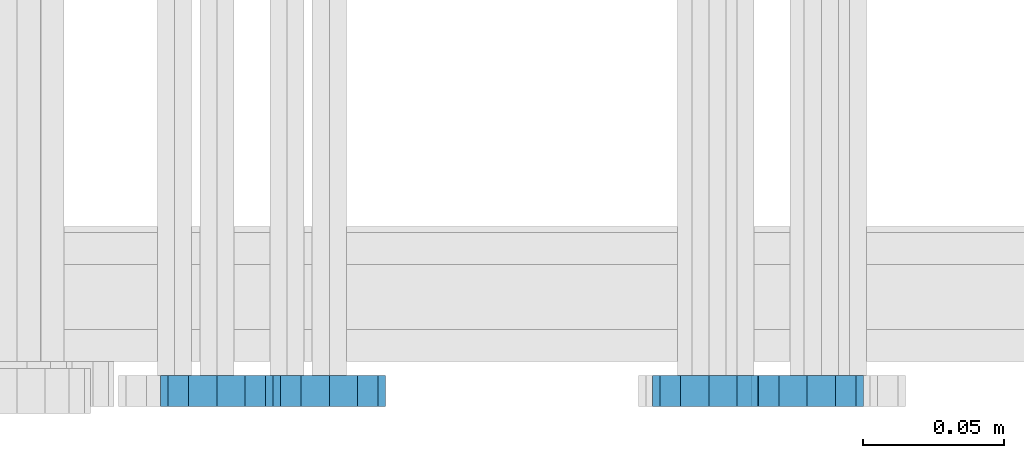
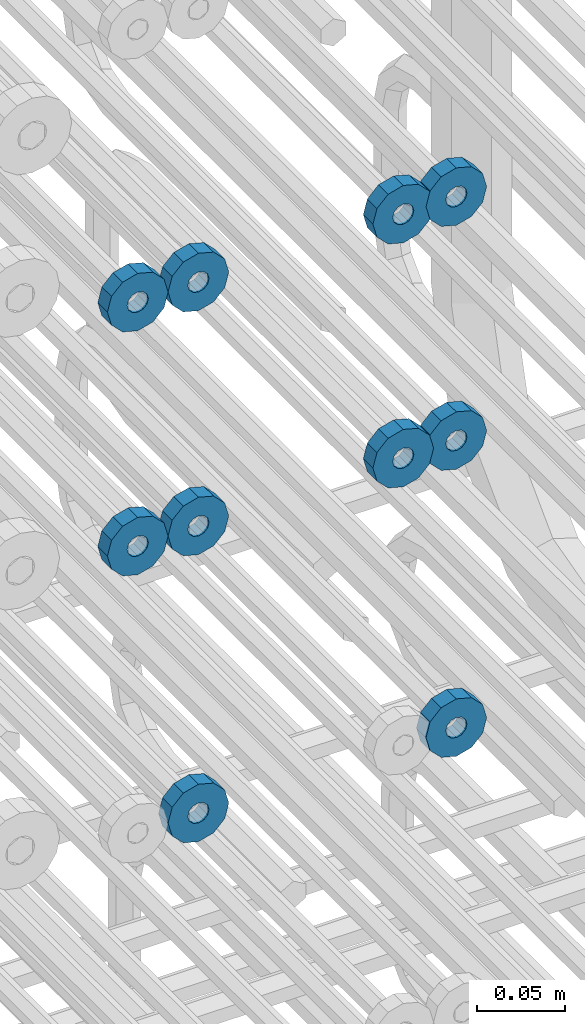
# One storey, part 157 of 177: 10 beams.
"""IFC2X3 building model written with IfcOpenShell, lengths in millimetres."""

from ifc_helpers import new_model, si_unit, frame, origin_with_axes, place, context, subcontext, project, spatial, faceted_brep, material, type_object, element, save


model = new_model("IFC2X3")

# Units and contexts
model_context_1 = context("Model", 3, precision=1e-05, world=origin_with_axes())
model_context_2 = context("Model", 3, precision=1e-05, world=origin_with_axes())
body_context = subcontext(model_context_2, "Body", "Model", "MODEL_VIEW")
ifc_project = project(units=[si_unit("LENGTHUNIT", "METRE", prefix="MILLI"), si_unit("AREAUNIT", "SQUARE_METRE"), si_unit("VOLUMEUNIT", "CUBIC_METRE"), si_unit("MASSUNIT", "GRAM", prefix="KILO"), si_unit("TIMEUNIT", "SECOND"), si_unit("PLANEANGLEUNIT", "RADIAN"), si_unit("SOLIDANGLEUNIT", "STERADIAN"), si_unit("THERMODYNAMICTEMPERATUREUNIT", "DEGREE_CELSIUS"), si_unit("LUMINOUSINTENSITYUNIT", "LUMEN")], contexts=[model_context_1])

# Site, building, storey
site_placement = place(None, origin_with_axes())
site = spatial("IfcSite", under=ifc_project, at=site_placement, CompositionType="ELEMENT")
building_placement = place(site_placement, origin_with_axes())
building = spatial("IfcBuilding", under=site, at=building_placement, Name="Undefined", CompositionType="ELEMENT")
storey_placement = place(building_placement, origin_with_axes())
storey = spatial("IfcBuildingStorey", under=building, at=storey_placement, Name="Undefined", CompositionType="ELEMENT", Elevation=0.0)

# Beams
ifc_material = material(Name="STEEL/Steel_Undefined")
beam_type = type_object("IfcBeamType", PredefinedType="NOTDEFINED")
beam_1_placement = place(storey_placement, frame((2035816.99847313, 6205070.98588032, 22114.9868114202), z_axis=(0.0, 0.0, -1.0), x_axis=(0.0, -1.0, 0.0)))
element("IfcBeam", 1, at=beam_1_placement, inside=storey, type_object=beam_type, material=ifc_material, context=body_context, shape_type="Brep", body=[
    faceted_brep([(-3.63797880709171e-12, -7.0, -2.3283064365387e-10), (-8.62348444298797e-13, -6.06217782649107, 3.5), (10.9999999999964, -6.06217782665044, 3.49999999976717), (10.9999999999964, -7.0, -2.3283064365387e-10), (-3.63797880709171e-12, -3.5, 6.06217782618478), (11.0, -3.5, 6.06217782618478), (-1.72469688859759e-12, 0.0, 7.0), (11.0, 0.0, 6.99999999976717), (-3.63797880709171e-12, 3.5, 6.06217782618478), (11.0, 3.5, 6.06217782618478), (-8.62348444298795e-13, 6.06217782649107, 3.5), (10.9999999999964, 6.06217782665044, 3.49999999976717), (-3.63797880709171e-12, 7.0, -2.3283064365387e-10), (10.9999999999964, 7.0, -2.3283064365387e-10), (8.62348444298797e-13, 6.06217782649107, -3.5), (10.9999999999964, 6.06217782665044, -3.50000000023283), (-3.63797880709171e-12, 3.5, -6.06217782665044), (10.9999999999964, 3.5, -6.06217782665044), (1.72469688859759e-12, -2.72004641033163e-15, -7.0), (10.9999999999964, 0.0, -7.00000000023283), (-3.63797880709171e-12, -3.5, -6.06217782665044), (10.9999999999964, -3.5, -6.06217782665044), (8.62348444298796e-13, -6.06217782649107, -3.5), (10.9999999999964, -6.06217782665044, -3.50000000023283), (0.0, -20.0000000009313, 0.0), (0.0, -17.320508075878, -10.0), (10.9999999999964, -17.320508075878, -10.0000000002328), (10.9999999999964, -20.0, -2.3283064365387e-10), (0.0, -10.0000000009313, -17.3205080756452), (11.0, -10.0, -17.320508075878), (0.0, -1.86264514923096e-09, -19.9999999998836), (10.9999999999964, 0.0, -20.0000000002328), (0.0, 9.99999999906868, -17.3205080755288), (11.0, 10.0, -17.320508075878), (0.0, 17.320508075878, -10.0), (10.9999999999964, 17.320508075878, -10.0000000002328), (0.0, 19.9999999990687, 0.0), (10.9999999999964, 20.0, -2.3283064365387e-10), (0.0, 17.3205080740154, 10.0), (11.0, 17.320508075878, 9.99999999976717), (0.0, 9.99999999906868, 17.3205080757616), (10.9999999999964, 10.0, 17.3205080754124), (0.0, 0.0, 20.0000000001164), (10.9999999999964, 0.0, 19.9999999997672), (0.0, -10.0000000009313, 17.3205080757616), (10.9999999999964, -10.0, 17.3205080754124), (0.0, -17.3205080777407, 10.0000000001164), (11.0, -17.320508075878, 9.99999999976717)], [[[0, 1, 2, 3]], [[1, 4, 5, 2]], [[4, 6, 7, 5]], [[6, 8, 9, 7]], [[8, 10, 11, 9]], [[10, 12, 13, 11]], [[12, 14, 15, 13]], [[14, 16, 17, 15]], [[16, 18, 19, 17]], [[18, 20, 21, 19]], [[20, 22, 23, 21]], [[22, 0, 3, 23]], [[24, 25, 26, 27]], [[25, 28, 29, 26]], [[28, 30, 31, 29]], [[30, 32, 33, 31]], [[32, 34, 35, 33]], [[34, 36, 37, 35]], [[36, 38, 39, 37]], [[38, 40, 41, 39]], [[40, 42, 43, 41]], [[42, 44, 45, 43]], [[44, 46, 47, 45]], [[46, 24, 27, 47]], [[29, 31, 33, 35, 37, 39, 41, 43, 45, 47, 27, 26], [5, 7, 9, 11, 13, 15, 17, 19, 21, 23, 3, 2]], [[46, 44, 42, 40, 38, 36, 34, 32, 30, 28, 25, 24], [22, 20, 18, 16, 14, 12, 10, 8, 6, 4, 1, 0]]]),
])
beam_2_placement = place(storey_placement, frame((2035646.99847313, 6205070.98588032, 22114.9868114254), z_axis=(0.0, 0.0, -1.0), x_axis=(0.0, -1.0, 0.0)))
element("IfcBeam", 2, at=beam_2_placement, inside=storey, type_object=beam_type, material=ifc_material, context=body_context, shape_type="Brep", body=[
    faceted_brep([(-3.63797880709171e-12, -7.0, -2.3283064365387e-10), (-8.62348444298797e-13, -6.06217782649107, 3.5), (10.9999999999964, -6.06217782665044, 3.49999999976717), (10.9999999999964, -7.0, -2.3283064365387e-10), (-3.63797880709171e-12, -3.5, 6.06217782618478), (11.0, -3.5, 6.06217782618478), (-1.72469688859759e-12, 0.0, 7.0), (11.0, 0.0, 6.99999999976717), (-3.63797880709171e-12, 3.5, 6.06217782618478), (11.0, 3.5, 6.06217782618478), (-8.62348444298795e-13, 6.06217782649107, 3.5), (10.9999999999964, 6.06217782665044, 3.49999999976717), (-3.63797880709171e-12, 7.0, -2.3283064365387e-10), (10.9999999999964, 7.0, -2.3283064365387e-10), (8.62348444298797e-13, 6.06217782649107, -3.5), (10.9999999999964, 6.06217782665044, -3.50000000023283), (-3.63797880709171e-12, 3.5, -6.06217782665044), (10.9999999999964, 3.5, -6.06217782665044), (1.72469688859759e-12, -2.72004641033163e-15, -7.0), (10.9999999999964, 0.0, -7.00000000023283), (-3.63797880709171e-12, -3.5, -6.06217782665044), (10.9999999999964, -3.5, -6.06217782665044), (8.62348444298796e-13, -6.06217782649107, -3.5), (10.9999999999964, -6.06217782665044, -3.50000000023283), (0.0, -20.0000000009313, 0.0), (0.0, -17.320508075878, -10.0), (10.9999999999964, -17.320508075878, -10.0000000002328), (10.9999999999964, -20.0, -2.3283064365387e-10), (0.0, -10.0000000009313, -17.3205080756452), (11.0, -10.0, -17.320508075878), (0.0, -1.86264514923096e-09, -19.9999999998836), (10.9999999999964, 0.0, -20.0000000002328), (0.0, 9.99999999906868, -17.3205080755288), (11.0, 10.0, -17.320508075878), (0.0, 17.320508075878, -10.0), (10.9999999999964, 17.320508075878, -10.0000000002328), (0.0, 19.9999999990687, 0.0), (10.9999999999964, 20.0, -2.3283064365387e-10), (0.0, 17.3205080740154, 10.0), (11.0, 17.320508075878, 9.99999999976717), (0.0, 9.99999999906868, 17.3205080757616), (10.9999999999964, 10.0, 17.3205080754124), (0.0, 0.0, 20.0000000001164), (10.9999999999964, 0.0, 19.9999999997672), (0.0, -10.0000000009313, 17.3205080757616), (10.9999999999964, -10.0, 17.3205080754124), (0.0, -17.3205080777407, 10.0000000001164), (11.0, -17.320508075878, 9.99999999976717)], [[[0, 1, 2, 3]], [[1, 4, 5, 2]], [[4, 6, 7, 5]], [[6, 8, 9, 7]], [[8, 10, 11, 9]], [[10, 12, 13, 11]], [[12, 14, 15, 13]], [[14, 16, 17, 15]], [[16, 18, 19, 17]], [[18, 20, 21, 19]], [[20, 22, 23, 21]], [[22, 0, 3, 23]], [[24, 25, 26, 27]], [[25, 28, 29, 26]], [[28, 30, 31, 29]], [[30, 32, 33, 31]], [[32, 34, 35, 33]], [[34, 36, 37, 35]], [[36, 38, 39, 37]], [[38, 40, 41, 39]], [[40, 42, 43, 41]], [[42, 44, 45, 43]], [[44, 46, 47, 45]], [[46, 24, 27, 47]], [[29, 31, 33, 35, 37, 39, 41, 43, 45, 47, 27, 26], [5, 7, 9, 11, 13, 15, 17, 19, 21, 23, 3, 2]], [[46, 44, 42, 40, 38, 36, 34, 32, 30, 28, 25, 24], [22, 20, 18, 16, 14, 12, 10, 8, 6, 4, 1, 0]]]),
])
beam_3_placement = place(storey_placement, frame((2035781.99847313, 6205070.98588032, 22114.9868114202), z_axis=(0.0, 0.0, -1.0), x_axis=(0.0, -1.0, 0.0)))
element("IfcBeam", 3, at=beam_3_placement, inside=storey, type_object=beam_type, material=ifc_material, context=body_context, shape_type="Brep", body=[
    faceted_brep([(-3.63797880709171e-12, -7.0, -2.3283064365387e-10), (-8.62348444298797e-13, -6.06217782649107, 3.5), (10.9999999999964, -6.06217782665044, 3.49999999976717), (10.9999999999964, -7.0, -2.3283064365387e-10), (-3.63797880709171e-12, -3.5, 6.06217782618478), (11.0, -3.5, 6.06217782618478), (-1.72469688859759e-12, 0.0, 7.0), (11.0, 0.0, 6.99999999976717), (-3.63797880709171e-12, 3.5, 6.06217782618478), (11.0, 3.5, 6.06217782618478), (-8.62348444298795e-13, 6.06217782649107, 3.5), (10.9999999999964, 6.06217782665044, 3.49999999976717), (-3.63797880709171e-12, 7.0, -2.3283064365387e-10), (10.9999999999964, 7.0, -2.3283064365387e-10), (8.62348444298797e-13, 6.06217782649107, -3.5), (10.9999999999964, 6.06217782665044, -3.50000000023283), (-3.63797880709171e-12, 3.5, -6.06217782665044), (10.9999999999964, 3.5, -6.06217782665044), (1.72469688859759e-12, -2.72004641033163e-15, -7.0), (10.9999999999964, 0.0, -7.00000000023283), (-3.63797880709171e-12, -3.5, -6.06217782665044), (10.9999999999964, -3.5, -6.06217782665044), (8.62348444298796e-13, -6.06217782649107, -3.5), (10.9999999999964, -6.06217782665044, -3.50000000023283), (0.0, -20.0000000009313, 0.0), (0.0, -17.320508075878, -10.0), (10.9999999999964, -17.320508075878, -10.0000000002328), (10.9999999999964, -20.0, -2.3283064365387e-10), (0.0, -10.0000000009313, -17.3205080756452), (11.0, -10.0, -17.320508075878), (0.0, -1.86264514923096e-09, -19.9999999998836), (10.9999999999964, 0.0, -20.0000000002328), (0.0, 9.99999999906868, -17.3205080755288), (11.0, 10.0, -17.320508075878), (0.0, 17.320508075878, -10.0), (10.9999999999964, 17.320508075878, -10.0000000002328), (0.0, 19.9999999990687, 0.0), (10.9999999999964, 20.0, -2.3283064365387e-10), (0.0, 17.3205080740154, 10.0), (11.0, 17.320508075878, 9.99999999976717), (0.0, 9.99999999906868, 17.3205080757616), (10.9999999999964, 10.0, 17.3205080754124), (0.0, 0.0, 20.0000000001164), (10.9999999999964, 0.0, 19.9999999997672), (0.0, -10.0000000009313, 17.3205080757616), (10.9999999999964, -10.0, 17.3205080754124), (0.0, -17.3205080777407, 10.0000000001164), (11.0, -17.320508075878, 9.99999999976717)], [[[0, 1, 2, 3]], [[1, 4, 5, 2]], [[4, 6, 7, 5]], [[6, 8, 9, 7]], [[8, 10, 11, 9]], [[10, 12, 13, 11]], [[12, 14, 15, 13]], [[14, 16, 17, 15]], [[16, 18, 19, 17]], [[18, 20, 21, 19]], [[20, 22, 23, 21]], [[22, 0, 3, 23]], [[24, 25, 26, 27]], [[25, 28, 29, 26]], [[28, 30, 31, 29]], [[30, 32, 33, 31]], [[32, 34, 35, 33]], [[34, 36, 37, 35]], [[36, 38, 39, 37]], [[38, 40, 41, 39]], [[40, 42, 43, 41]], [[42, 44, 45, 43]], [[44, 46, 47, 45]], [[46, 24, 27, 47]], [[29, 31, 33, 35, 37, 39, 41, 43, 45, 47, 27, 26], [5, 7, 9, 11, 13, 15, 17, 19, 21, 23, 3, 2]], [[46, 44, 42, 40, 38, 36, 34, 32, 30, 28, 25, 24], [22, 20, 18, 16, 14, 12, 10, 8, 6, 4, 1, 0]]]),
])
beam_4_placement = place(storey_placement, frame((2035606.99847313, 6205070.98588032, 22114.9868114254), z_axis=(0.0, 0.0, -1.0), x_axis=(0.0, -1.0, 0.0)))
element("IfcBeam", 4, at=beam_4_placement, inside=storey, type_object=beam_type, material=ifc_material, context=body_context, shape_type="Brep", body=[
    faceted_brep([(-3.63797880709171e-12, -7.0, -2.3283064365387e-10), (-8.62348444298797e-13, -6.06217782649107, 3.5), (10.9999999999964, -6.06217782665044, 3.49999999976717), (10.9999999999964, -7.0, -2.3283064365387e-10), (-3.63797880709171e-12, -3.5, 6.06217782618478), (11.0, -3.5, 6.06217782618478), (-1.72469688859759e-12, 0.0, 7.0), (11.0, 0.0, 6.99999999976717), (-3.63797880709171e-12, 3.5, 6.06217782618478), (11.0, 3.5, 6.06217782618478), (-8.62348444298795e-13, 6.06217782649107, 3.5), (10.9999999999964, 6.06217782665044, 3.49999999976717), (-3.63797880709171e-12, 7.0, -2.3283064365387e-10), (10.9999999999964, 7.0, -2.3283064365387e-10), (8.62348444298797e-13, 6.06217782649107, -3.5), (10.9999999999964, 6.06217782665044, -3.50000000023283), (-3.63797880709171e-12, 3.5, -6.06217782665044), (10.9999999999964, 3.5, -6.06217782665044), (1.72469688859759e-12, -2.72004641033163e-15, -7.0), (10.9999999999964, 0.0, -7.00000000023283), (-3.63797880709171e-12, -3.5, -6.06217782665044), (10.9999999999964, -3.5, -6.06217782665044), (8.62348444298796e-13, -6.06217782649107, -3.5), (10.9999999999964, -6.06217782665044, -3.50000000023283), (0.0, -20.0000000009313, 0.0), (0.0, -17.320508075878, -10.0), (10.9999999999964, -17.320508075878, -10.0000000002328), (10.9999999999964, -20.0, -2.3283064365387e-10), (0.0, -10.0000000009313, -17.3205080756452), (11.0, -10.0, -17.320508075878), (0.0, -1.86264514923096e-09, -19.9999999998836), (10.9999999999964, 0.0, -20.0000000002328), (0.0, 9.99999999906868, -17.3205080755288), (11.0, 10.0, -17.320508075878), (0.0, 17.320508075878, -10.0), (10.9999999999964, 17.320508075878, -10.0000000002328), (0.0, 19.9999999990687, 0.0), (10.9999999999964, 20.0, -2.3283064365387e-10), (0.0, 17.3205080740154, 10.0), (11.0, 17.320508075878, 9.99999999976717), (0.0, 9.99999999906868, 17.3205080757616), (10.9999999999964, 10.0, 17.3205080754124), (0.0, 0.0, 20.0000000001164), (10.9999999999964, 0.0, 19.9999999997672), (0.0, -10.0000000009313, 17.3205080757616), (10.9999999999964, -10.0, 17.3205080754124), (0.0, -17.3205080777407, 10.0000000001164), (11.0, -17.320508075878, 9.99999999976717)], [[[0, 1, 2, 3]], [[1, 4, 5, 2]], [[4, 6, 7, 5]], [[6, 8, 9, 7]], [[8, 10, 11, 9]], [[10, 12, 13, 11]], [[12, 14, 15, 13]], [[14, 16, 17, 15]], [[16, 18, 19, 17]], [[18, 20, 21, 19]], [[20, 22, 23, 21]], [[22, 0, 3, 23]], [[24, 25, 26, 27]], [[25, 28, 29, 26]], [[28, 30, 31, 29]], [[30, 32, 33, 31]], [[32, 34, 35, 33]], [[34, 36, 37, 35]], [[36, 38, 39, 37]], [[38, 40, 41, 39]], [[40, 42, 43, 41]], [[42, 44, 45, 43]], [[44, 46, 47, 45]], [[46, 24, 27, 47]], [[29, 31, 33, 35, 37, 39, 41, 43, 45, 47, 27, 26], [5, 7, 9, 11, 13, 15, 17, 19, 21, 23, 3, 2]], [[46, 44, 42, 40, 38, 36, 34, 32, 30, 28, 25, 24], [22, 20, 18, 16, 14, 12, 10, 8, 6, 4, 1, 0]]]),
])
beam_5_placement = place(storey_placement, frame((2035816.99847313, 6205070.98588032, 21944.9868114202), z_axis=(0.0, 0.0, -1.0), x_axis=(0.0, -1.0, 0.0)))
element("IfcBeam", 5, at=beam_5_placement, inside=storey, type_object=beam_type, material=ifc_material, context=body_context, shape_type="Brep", body=[
    faceted_brep([(-3.63797880709171e-12, -7.0, -2.3283064365387e-10), (-8.62348444298797e-13, -6.06217782649107, 3.5), (10.9999999999964, -6.06217782665044, 3.49999999976717), (10.9999999999964, -7.0, -2.3283064365387e-10), (-3.63797880709171e-12, -3.5, 6.06217782618478), (11.0, -3.5, 6.06217782618478), (-1.72469688859759e-12, 0.0, 7.0), (11.0, 0.0, 6.99999999976717), (-3.63797880709171e-12, 3.5, 6.06217782618478), (11.0, 3.5, 6.06217782618478), (-8.62348444298795e-13, 6.06217782649107, 3.5), (10.9999999999964, 6.06217782665044, 3.49999999976717), (-3.63797880709171e-12, 7.0, -2.3283064365387e-10), (10.9999999999964, 7.0, -2.3283064365387e-10), (8.62348444298797e-13, 6.06217782649107, -3.5), (10.9999999999964, 6.06217782665044, -3.50000000023283), (-3.63797880709171e-12, 3.5, -6.06217782665044), (10.9999999999964, 3.5, -6.06217782665044), (1.72469688859759e-12, -2.72004641033163e-15, -7.0), (10.9999999999964, 0.0, -7.00000000023283), (-3.63797880709171e-12, -3.5, -6.06217782665044), (10.9999999999964, -3.5, -6.06217782665044), (8.62348444298796e-13, -6.06217782649107, -3.5), (10.9999999999964, -6.06217782665044, -3.50000000023283), (0.0, -20.0000000009313, 0.0), (0.0, -17.320508075878, -10.0), (10.9999999999964, -17.320508075878, -10.0000000002328), (10.9999999999964, -20.0, -2.3283064365387e-10), (0.0, -10.0000000009313, -17.3205080756452), (11.0, -10.0, -17.320508075878), (0.0, -1.86264514923096e-09, -19.9999999998836), (10.9999999999964, 0.0, -20.0000000002328), (0.0, 9.99999999906868, -17.3205080755288), (11.0, 10.0, -17.320508075878), (0.0, 17.320508075878, -10.0), (10.9999999999964, 17.320508075878, -10.0000000002328), (0.0, 19.9999999990687, 0.0), (10.9999999999964, 20.0, -2.3283064365387e-10), (0.0, 17.3205080740154, 10.0), (11.0, 17.320508075878, 9.99999999976717), (0.0, 9.99999999906868, 17.3205080757616), (10.9999999999964, 10.0, 17.3205080754124), (0.0, 0.0, 20.0000000001164), (10.9999999999964, 0.0, 19.9999999997672), (0.0, -10.0000000009313, 17.3205080757616), (10.9999999999964, -10.0, 17.3205080754124), (0.0, -17.3205080777407, 10.0000000001164), (11.0, -17.320508075878, 9.99999999976717)], [[[0, 1, 2, 3]], [[1, 4, 5, 2]], [[4, 6, 7, 5]], [[6, 8, 9, 7]], [[8, 10, 11, 9]], [[10, 12, 13, 11]], [[12, 14, 15, 13]], [[14, 16, 17, 15]], [[16, 18, 19, 17]], [[18, 20, 21, 19]], [[20, 22, 23, 21]], [[22, 0, 3, 23]], [[24, 25, 26, 27]], [[25, 28, 29, 26]], [[28, 30, 31, 29]], [[30, 32, 33, 31]], [[32, 34, 35, 33]], [[34, 36, 37, 35]], [[36, 38, 39, 37]], [[38, 40, 41, 39]], [[40, 42, 43, 41]], [[42, 44, 45, 43]], [[44, 46, 47, 45]], [[46, 24, 27, 47]], [[29, 31, 33, 35, 37, 39, 41, 43, 45, 47, 27, 26], [5, 7, 9, 11, 13, 15, 17, 19, 21, 23, 3, 2]], [[46, 44, 42, 40, 38, 36, 34, 32, 30, 28, 25, 24], [22, 20, 18, 16, 14, 12, 10, 8, 6, 4, 1, 0]]]),
])
beam_6_placement = place(storey_placement, frame((2035646.99847313, 6205070.98588032, 21944.9868114254), z_axis=(0.0, 0.0, -1.0), x_axis=(0.0, -1.0, 0.0)))
element("IfcBeam", 6, at=beam_6_placement, inside=storey, type_object=beam_type, material=ifc_material, context=body_context, shape_type="Brep", body=[
    faceted_brep([(-3.63797880709171e-12, -7.0, -2.3283064365387e-10), (-8.62348444298797e-13, -6.06217782649107, 3.5), (10.9999999999964, -6.06217782665044, 3.49999999976717), (10.9999999999964, -7.0, -2.3283064365387e-10), (-3.63797880709171e-12, -3.5, 6.06217782618478), (11.0, -3.5, 6.06217782618478), (-1.72469688859759e-12, 0.0, 7.0), (11.0, 0.0, 6.99999999976717), (-3.63797880709171e-12, 3.5, 6.06217782618478), (11.0, 3.5, 6.06217782618478), (-8.62348444298795e-13, 6.06217782649107, 3.5), (10.9999999999964, 6.06217782665044, 3.49999999976717), (-3.63797880709171e-12, 7.0, -2.3283064365387e-10), (10.9999999999964, 7.0, -2.3283064365387e-10), (8.62348444298797e-13, 6.06217782649107, -3.5), (10.9999999999964, 6.06217782665044, -3.50000000023283), (-3.63797880709171e-12, 3.5, -6.06217782665044), (10.9999999999964, 3.5, -6.06217782665044), (1.72469688859759e-12, -2.72004641033163e-15, -7.0), (10.9999999999964, 0.0, -7.00000000023283), (-3.63797880709171e-12, -3.5, -6.06217782665044), (10.9999999999964, -3.5, -6.06217782665044), (8.62348444298796e-13, -6.06217782649107, -3.5), (10.9999999999964, -6.06217782665044, -3.50000000023283), (0.0, -20.0000000009313, 0.0), (0.0, -17.320508075878, -10.0), (10.9999999999964, -17.320508075878, -10.0000000002328), (10.9999999999964, -20.0, -2.3283064365387e-10), (0.0, -10.0000000009313, -17.3205080756452), (11.0, -10.0, -17.320508075878), (0.0, -1.86264514923096e-09, -19.9999999998836), (10.9999999999964, 0.0, -20.0000000002328), (0.0, 9.99999999906868, -17.3205080755288), (11.0, 10.0, -17.320508075878), (0.0, 17.320508075878, -10.0), (10.9999999999964, 17.320508075878, -10.0000000002328), (0.0, 19.9999999990687, 0.0), (10.9999999999964, 20.0, -2.3283064365387e-10), (0.0, 17.3205080740154, 10.0), (11.0, 17.320508075878, 9.99999999976717), (0.0, 9.99999999906868, 17.3205080757616), (10.9999999999964, 10.0, 17.3205080754124), (0.0, 0.0, 20.0000000001164), (10.9999999999964, 0.0, 19.9999999997672), (0.0, -10.0000000009313, 17.3205080757616), (10.9999999999964, -10.0, 17.3205080754124), (0.0, -17.3205080777407, 10.0000000001164), (11.0, -17.320508075878, 9.99999999976717)], [[[0, 1, 2, 3]], [[1, 4, 5, 2]], [[4, 6, 7, 5]], [[6, 8, 9, 7]], [[8, 10, 11, 9]], [[10, 12, 13, 11]], [[12, 14, 15, 13]], [[14, 16, 17, 15]], [[16, 18, 19, 17]], [[18, 20, 21, 19]], [[20, 22, 23, 21]], [[22, 0, 3, 23]], [[24, 25, 26, 27]], [[25, 28, 29, 26]], [[28, 30, 31, 29]], [[30, 32, 33, 31]], [[32, 34, 35, 33]], [[34, 36, 37, 35]], [[36, 38, 39, 37]], [[38, 40, 41, 39]], [[40, 42, 43, 41]], [[42, 44, 45, 43]], [[44, 46, 47, 45]], [[46, 24, 27, 47]], [[29, 31, 33, 35, 37, 39, 41, 43, 45, 47, 27, 26], [5, 7, 9, 11, 13, 15, 17, 19, 21, 23, 3, 2]], [[46, 44, 42, 40, 38, 36, 34, 32, 30, 28, 25, 24], [22, 20, 18, 16, 14, 12, 10, 8, 6, 4, 1, 0]]]),
])
beam_7_placement = place(storey_placement, frame((2035781.99847313, 6205070.98588032, 21944.9868114202), z_axis=(0.0, 0.0, -1.0), x_axis=(0.0, -1.0, 0.0)))
element("IfcBeam", 7, at=beam_7_placement, inside=storey, type_object=beam_type, material=ifc_material, context=body_context, shape_type="Brep", body=[
    faceted_brep([(-3.63797880709171e-12, -7.0, -2.3283064365387e-10), (-8.62348444298797e-13, -6.06217782649107, 3.5), (10.9999999999964, -6.06217782665044, 3.49999999976717), (10.9999999999964, -7.0, -2.3283064365387e-10), (-3.63797880709171e-12, -3.5, 6.06217782618478), (11.0, -3.5, 6.06217782618478), (-1.72469688859759e-12, 0.0, 7.0), (11.0, 0.0, 6.99999999976717), (-3.63797880709171e-12, 3.5, 6.06217782618478), (11.0, 3.5, 6.06217782618478), (-8.62348444298795e-13, 6.06217782649107, 3.5), (10.9999999999964, 6.06217782665044, 3.49999999976717), (-3.63797880709171e-12, 7.0, -2.3283064365387e-10), (10.9999999999964, 7.0, -2.3283064365387e-10), (8.62348444298797e-13, 6.06217782649107, -3.5), (10.9999999999964, 6.06217782665044, -3.50000000023283), (-3.63797880709171e-12, 3.5, -6.06217782665044), (10.9999999999964, 3.5, -6.06217782665044), (1.72469688859759e-12, -2.72004641033163e-15, -7.0), (10.9999999999964, 0.0, -7.00000000023283), (-3.63797880709171e-12, -3.5, -6.06217782665044), (10.9999999999964, -3.5, -6.06217782665044), (8.62348444298796e-13, -6.06217782649107, -3.5), (10.9999999999964, -6.06217782665044, -3.50000000023283), (0.0, -20.0000000009313, 0.0), (0.0, -17.320508075878, -10.0), (10.9999999999964, -17.320508075878, -10.0000000002328), (10.9999999999964, -20.0, -2.3283064365387e-10), (0.0, -10.0000000009313, -17.3205080756452), (11.0, -10.0, -17.320508075878), (0.0, -1.86264514923096e-09, -19.9999999998836), (10.9999999999964, 0.0, -20.0000000002328), (0.0, 9.99999999906868, -17.3205080755288), (11.0, 10.0, -17.320508075878), (0.0, 17.320508075878, -10.0), (10.9999999999964, 17.320508075878, -10.0000000002328), (0.0, 19.9999999990687, 0.0), (10.9999999999964, 20.0, -2.3283064365387e-10), (0.0, 17.3205080740154, 10.0), (11.0, 17.320508075878, 9.99999999976717), (0.0, 9.99999999906868, 17.3205080757616), (10.9999999999964, 10.0, 17.3205080754124), (0.0, 0.0, 20.0000000001164), (10.9999999999964, 0.0, 19.9999999997672), (0.0, -10.0000000009313, 17.3205080757616), (10.9999999999964, -10.0, 17.3205080754124), (0.0, -17.3205080777407, 10.0000000001164), (11.0, -17.320508075878, 9.99999999976717)], [[[0, 1, 2, 3]], [[1, 4, 5, 2]], [[4, 6, 7, 5]], [[6, 8, 9, 7]], [[8, 10, 11, 9]], [[10, 12, 13, 11]], [[12, 14, 15, 13]], [[14, 16, 17, 15]], [[16, 18, 19, 17]], [[18, 20, 21, 19]], [[20, 22, 23, 21]], [[22, 0, 3, 23]], [[24, 25, 26, 27]], [[25, 28, 29, 26]], [[28, 30, 31, 29]], [[30, 32, 33, 31]], [[32, 34, 35, 33]], [[34, 36, 37, 35]], [[36, 38, 39, 37]], [[38, 40, 41, 39]], [[40, 42, 43, 41]], [[42, 44, 45, 43]], [[44, 46, 47, 45]], [[46, 24, 27, 47]], [[29, 31, 33, 35, 37, 39, 41, 43, 45, 47, 27, 26], [5, 7, 9, 11, 13, 15, 17, 19, 21, 23, 3, 2]], [[46, 44, 42, 40, 38, 36, 34, 32, 30, 28, 25, 24], [22, 20, 18, 16, 14, 12, 10, 8, 6, 4, 1, 0]]]),
])
beam_8_placement = place(storey_placement, frame((2035606.99847313, 6205070.98588032, 21944.9868114254), z_axis=(0.0, 0.0, -1.0), x_axis=(0.0, -1.0, 0.0)))
element("IfcBeam", 8, at=beam_8_placement, inside=storey, type_object=beam_type, material=ifc_material, context=body_context, shape_type="Brep", body=[
    faceted_brep([(-3.63797880709171e-12, -7.0, -2.3283064365387e-10), (-8.62348444298797e-13, -6.06217782649107, 3.5), (10.9999999999964, -6.06217782665044, 3.49999999976717), (10.9999999999964, -7.0, -2.3283064365387e-10), (-3.63797880709171e-12, -3.5, 6.06217782618478), (11.0, -3.5, 6.06217782618478), (-1.72469688859759e-12, 0.0, 7.0), (11.0, 0.0, 6.99999999976717), (-3.63797880709171e-12, 3.5, 6.06217782618478), (11.0, 3.5, 6.06217782618478), (-8.62348444298795e-13, 6.06217782649107, 3.5), (10.9999999999964, 6.06217782665044, 3.49999999976717), (-3.63797880709171e-12, 7.0, -2.3283064365387e-10), (10.9999999999964, 7.0, -2.3283064365387e-10), (8.62348444298797e-13, 6.06217782649107, -3.5), (10.9999999999964, 6.06217782665044, -3.50000000023283), (-3.63797880709171e-12, 3.5, -6.06217782665044), (10.9999999999964, 3.5, -6.06217782665044), (1.72469688859759e-12, -2.72004641033163e-15, -7.0), (10.9999999999964, 0.0, -7.00000000023283), (-3.63797880709171e-12, -3.5, -6.06217782665044), (10.9999999999964, -3.5, -6.06217782665044), (8.62348444298796e-13, -6.06217782649107, -3.5), (10.9999999999964, -6.06217782665044, -3.50000000023283), (0.0, -20.0000000009313, 0.0), (0.0, -17.320508075878, -10.0), (10.9999999999964, -17.320508075878, -10.0000000002328), (10.9999999999964, -20.0, -2.3283064365387e-10), (0.0, -10.0000000009313, -17.3205080756452), (11.0, -10.0, -17.320508075878), (0.0, -1.86264514923096e-09, -19.9999999998836), (10.9999999999964, 0.0, -20.0000000002328), (0.0, 9.99999999906868, -17.3205080755288), (11.0, 10.0, -17.320508075878), (0.0, 17.320508075878, -10.0), (10.9999999999964, 17.320508075878, -10.0000000002328), (0.0, 19.9999999990687, 0.0), (10.9999999999964, 20.0, -2.3283064365387e-10), (0.0, 17.3205080740154, 10.0), (11.0, 17.320508075878, 9.99999999976717), (0.0, 9.99999999906868, 17.3205080757616), (10.9999999999964, 10.0, 17.3205080754124), (0.0, 0.0, 20.0000000001164), (10.9999999999964, 0.0, 19.9999999997672), (0.0, -10.0000000009313, 17.3205080757616), (10.9999999999964, -10.0, 17.3205080754124), (0.0, -17.3205080777407, 10.0000000001164), (11.0, -17.320508075878, 9.99999999976717)], [[[0, 1, 2, 3]], [[1, 4, 5, 2]], [[4, 6, 7, 5]], [[6, 8, 9, 7]], [[8, 10, 11, 9]], [[10, 12, 13, 11]], [[12, 14, 15, 13]], [[14, 16, 17, 15]], [[16, 18, 19, 17]], [[18, 20, 21, 19]], [[20, 22, 23, 21]], [[22, 0, 3, 23]], [[24, 25, 26, 27]], [[25, 28, 29, 26]], [[28, 30, 31, 29]], [[30, 32, 33, 31]], [[32, 34, 35, 33]], [[34, 36, 37, 35]], [[36, 38, 39, 37]], [[38, 40, 41, 39]], [[40, 42, 43, 41]], [[42, 44, 45, 43]], [[44, 46, 47, 45]], [[46, 24, 27, 47]], [[29, 31, 33, 35, 37, 39, 41, 43, 45, 47, 27, 26], [5, 7, 9, 11, 13, 15, 17, 19, 21, 23, 3, 2]], [[46, 44, 42, 40, 38, 36, 34, 32, 30, 28, 25, 24], [22, 20, 18, 16, 14, 12, 10, 8, 6, 4, 1, 0]]]),
])
beam_9_placement = place(storey_placement, frame((2035816.99847313, 6205070.98588032, 21744.9868114202), z_axis=(0.0, 0.0, -1.0), x_axis=(0.0, -1.0, 0.0)))
element("IfcBeam", 9, at=beam_9_placement, inside=storey, type_object=beam_type, material=ifc_material, context=body_context, shape_type="Brep", body=[
    faceted_brep([(-3.63797880709171e-12, -7.0, -2.3283064365387e-10), (-8.62348444298797e-13, -6.06217782649107, 3.5), (10.9999999999964, -6.06217782665044, 3.49999999976717), (10.9999999999964, -7.0, -2.3283064365387e-10), (-3.63797880709171e-12, -3.5, 6.06217782618478), (11.0, -3.5, 6.06217782618478), (-1.72469688859759e-12, 0.0, 7.0), (11.0, 0.0, 6.99999999976717), (-3.63797880709171e-12, 3.5, 6.06217782618478), (11.0, 3.5, 6.06217782618478), (-8.62348444298795e-13, 6.06217782649107, 3.5), (10.9999999999964, 6.06217782665044, 3.49999999976717), (-3.63797880709171e-12, 7.0, -2.3283064365387e-10), (10.9999999999964, 7.0, -2.3283064365387e-10), (8.62348444298797e-13, 6.06217782649107, -3.5), (10.9999999999964, 6.06217782665044, -3.50000000023283), (-3.63797880709171e-12, 3.5, -6.06217782665044), (10.9999999999964, 3.5, -6.06217782665044), (1.72469688859759e-12, -2.72004641033163e-15, -7.0), (10.9999999999964, 0.0, -7.00000000023283), (-3.63797880709171e-12, -3.5, -6.06217782665044), (10.9999999999964, -3.5, -6.06217782665044), (8.62348444298796e-13, -6.06217782649107, -3.5), (10.9999999999964, -6.06217782665044, -3.50000000023283), (0.0, -20.0000000009313, 0.0), (0.0, -17.320508075878, -10.0), (10.9999999999964, -17.320508075878, -10.0000000002328), (10.9999999999964, -20.0, -2.3283064365387e-10), (0.0, -10.0000000009313, -17.3205080756452), (11.0, -10.0, -17.320508075878), (0.0, -1.86264514923096e-09, -19.9999999998836), (10.9999999999964, 0.0, -20.0000000002328), (0.0, 9.99999999906868, -17.3205080755288), (11.0, 10.0, -17.320508075878), (0.0, 17.320508075878, -10.0), (10.9999999999964, 17.320508075878, -10.0000000002328), (0.0, 19.9999999990687, 0.0), (10.9999999999964, 20.0, -2.3283064365387e-10), (0.0, 17.3205080740154, 10.0), (11.0, 17.320508075878, 9.99999999976717), (0.0, 9.99999999906868, 17.3205080757616), (10.9999999999964, 10.0, 17.3205080754124), (0.0, 0.0, 20.0000000001164), (10.9999999999964, 0.0, 19.9999999997672), (0.0, -10.0000000009313, 17.3205080757616), (10.9999999999964, -10.0, 17.3205080754124), (0.0, -17.3205080777407, 10.0000000001164), (11.0, -17.320508075878, 9.99999999976717)], [[[0, 1, 2, 3]], [[1, 4, 5, 2]], [[4, 6, 7, 5]], [[6, 8, 9, 7]], [[8, 10, 11, 9]], [[10, 12, 13, 11]], [[12, 14, 15, 13]], [[14, 16, 17, 15]], [[16, 18, 19, 17]], [[18, 20, 21, 19]], [[20, 22, 23, 21]], [[22, 0, 3, 23]], [[24, 25, 26, 27]], [[25, 28, 29, 26]], [[28, 30, 31, 29]], [[30, 32, 33, 31]], [[32, 34, 35, 33]], [[34, 36, 37, 35]], [[36, 38, 39, 37]], [[38, 40, 41, 39]], [[40, 42, 43, 41]], [[42, 44, 45, 43]], [[44, 46, 47, 45]], [[46, 24, 27, 47]], [[29, 31, 33, 35, 37, 39, 41, 43, 45, 47, 27, 26], [5, 7, 9, 11, 13, 15, 17, 19, 21, 23, 3, 2]], [[46, 44, 42, 40, 38, 36, 34, 32, 30, 28, 25, 24], [22, 20, 18, 16, 14, 12, 10, 8, 6, 4, 1, 0]]]),
])
beam_10_placement = place(storey_placement, frame((2035646.99847313, 6205070.98588032, 21744.9868114254), z_axis=(0.0, 0.0, -1.0), x_axis=(0.0, -1.0, 0.0)))
element("IfcBeam", 10, at=beam_10_placement, inside=storey, type_object=beam_type, material=ifc_material, context=body_context, shape_type="Brep", body=[
    faceted_brep([(-3.63797880709171e-12, -7.0, -2.3283064365387e-10), (-8.62348444298797e-13, -6.06217782649107, 3.5), (10.9999999999964, -6.06217782665044, 3.49999999976717), (10.9999999999964, -7.0, -2.3283064365387e-10), (-3.63797880709171e-12, -3.5, 6.06217782618478), (11.0, -3.5, 6.06217782618478), (-1.72469688859759e-12, 0.0, 7.0), (11.0, 0.0, 6.99999999976717), (-3.63797880709171e-12, 3.5, 6.06217782618478), (11.0, 3.5, 6.06217782618478), (-8.62348444298795e-13, 6.06217782649107, 3.5), (10.9999999999964, 6.06217782665044, 3.49999999976717), (-3.63797880709171e-12, 7.0, -2.3283064365387e-10), (10.9999999999964, 7.0, -2.3283064365387e-10), (8.62348444298797e-13, 6.06217782649107, -3.5), (10.9999999999964, 6.06217782665044, -3.50000000023283), (-3.63797880709171e-12, 3.5, -6.06217782665044), (10.9999999999964, 3.5, -6.06217782665044), (1.72469688859759e-12, -2.72004641033163e-15, -7.0), (10.9999999999964, 0.0, -7.00000000023283), (-3.63797880709171e-12, -3.5, -6.06217782665044), (10.9999999999964, -3.5, -6.06217782665044), (8.62348444298796e-13, -6.06217782649107, -3.5), (10.9999999999964, -6.06217782665044, -3.50000000023283), (0.0, -20.0000000009313, 0.0), (0.0, -17.320508075878, -10.0), (10.9999999999964, -17.320508075878, -10.0000000002328), (10.9999999999964, -20.0, -2.3283064365387e-10), (0.0, -10.0000000009313, -17.3205080756452), (11.0, -10.0, -17.320508075878), (0.0, -1.86264514923096e-09, -19.9999999998836), (10.9999999999964, 0.0, -20.0000000002328), (0.0, 9.99999999906868, -17.3205080755288), (11.0, 10.0, -17.320508075878), (0.0, 17.320508075878, -10.0), (10.9999999999964, 17.320508075878, -10.0000000002328), (0.0, 19.9999999990687, 0.0), (10.9999999999964, 20.0, -2.3283064365387e-10), (0.0, 17.3205080740154, 10.0), (11.0, 17.320508075878, 9.99999999976717), (0.0, 9.99999999906868, 17.3205080757616), (10.9999999999964, 10.0, 17.3205080754124), (0.0, 0.0, 20.0000000001164), (10.9999999999964, 0.0, 19.9999999997672), (0.0, -10.0000000009313, 17.3205080757616), (10.9999999999964, -10.0, 17.3205080754124), (0.0, -17.3205080777407, 10.0000000001164), (11.0, -17.320508075878, 9.99999999976717)], [[[0, 1, 2, 3]], [[1, 4, 5, 2]], [[4, 6, 7, 5]], [[6, 8, 9, 7]], [[8, 10, 11, 9]], [[10, 12, 13, 11]], [[12, 14, 15, 13]], [[14, 16, 17, 15]], [[16, 18, 19, 17]], [[18, 20, 21, 19]], [[20, 22, 23, 21]], [[22, 0, 3, 23]], [[24, 25, 26, 27]], [[25, 28, 29, 26]], [[28, 30, 31, 29]], [[30, 32, 33, 31]], [[32, 34, 35, 33]], [[34, 36, 37, 35]], [[36, 38, 39, 37]], [[38, 40, 41, 39]], [[40, 42, 43, 41]], [[42, 44, 45, 43]], [[44, 46, 47, 45]], [[46, 24, 27, 47]], [[29, 31, 33, 35, 37, 39, 41, 43, 45, 47, 27, 26], [5, 7, 9, 11, 13, 15, 17, 19, 21, 23, 3, 2]], [[46, 44, 42, 40, 38, 36, 34, 32, 30, 28, 25, 24], [22, 20, 18, 16, 14, 12, 10, 8, 6, 4, 1, 0]]]),
])

save(model, "model.ifc")
